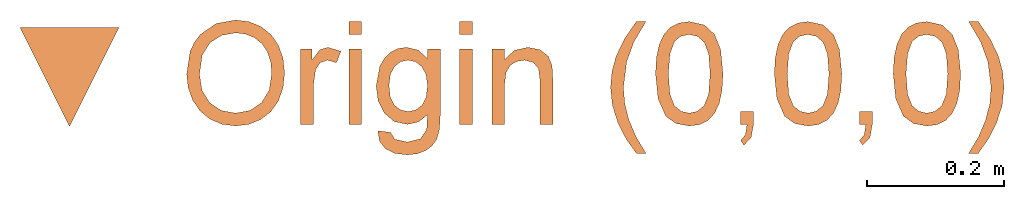
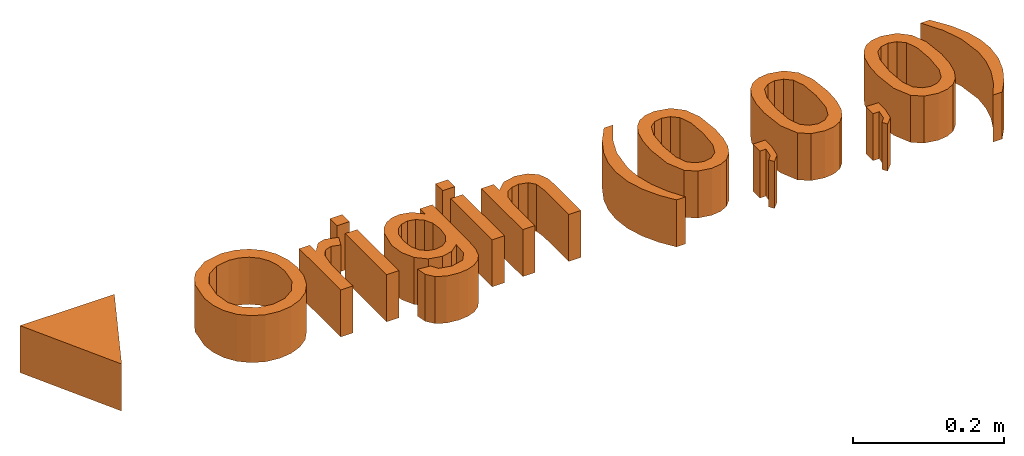
# One storey: 1 proxy.
"""IFC2X3 building model written with IfcOpenShell, lengths in feet."""

from ifc_helpers import new_model, entity, si_unit, converted_unit, derived_unit, direction, frame, frame_2d, origin, origin_2d_with_axis, place, context, subcontext, project, spatial, polyline, rectangle, outline, extrude, source, transform, mapped, element, save


model = new_model("IFC2X3")

# Units and contexts
model_context = context("Model", 3, precision=0.0001, world=origin(), true_north=direction((6.12303176911189e-17, 1.0)))
context_of_model = context(None, 3, precision=0.0001, world=origin(), true_north=direction((6.12303176911189e-17, 1.0)))
body_context = subcontext(model_context, "Body", "Model", "MODEL_VIEW")
ifc_project = project(units=[converted_unit("LENGTHUNIT", "FOOT", entity("IfcRatioMeasure", 0.3048), si_unit("LENGTHUNIT", "METRE"), dimensions=[1, 0, 0, 0, 0, 0, 0]), converted_unit("AREAUNIT", "SQUARE FOOT", entity("IfcRatioMeasure", 0.09290304), si_unit("AREAUNIT", "SQUARE_METRE"), dimensions=[2, 0, 0, 0, 0, 0, 0]), converted_unit("VOLUMEUNIT", "CUBIC FOOT", entity("IfcRatioMeasure", 0.028316846592), si_unit("VOLUMEUNIT", "CUBIC_METRE"), dimensions=[3, 0, 0, 0, 0, 0, 0]), converted_unit("PLANEANGLEUNIT", "DEGREE", entity("IfcRatioMeasure", 0.0174532925199433), si_unit("PLANEANGLEUNIT", "RADIAN"), dimensions=[0, 0, 0, 0, 0, 0, 0]), si_unit("MASSUNIT", "GRAM", prefix="KILO"), derived_unit("MASSDENSITYUNIT", [(si_unit("MASSUNIT", "GRAM", prefix="KILO"), 1), (si_unit("LENGTHUNIT", "METRE"), -3)]), si_unit("TIMEUNIT", "SECOND"), si_unit("FREQUENCYUNIT", "HERTZ"), si_unit("THERMODYNAMICTEMPERATUREUNIT", "DEGREE_CELSIUS"), derived_unit("THERMALTRANSMITTANCEUNIT", [(si_unit("MASSUNIT", "GRAM", prefix="KILO"), 1), (si_unit("THERMODYNAMICTEMPERATUREUNIT", "KELVIN"), -1), (si_unit("TIMEUNIT", "SECOND"), -3)]), derived_unit("VOLUMETRICFLOWRATEUNIT", [(si_unit("LENGTHUNIT", "METRE"), 3), (si_unit("TIMEUNIT", "SECOND"), -1)]), si_unit("ELECTRICCURRENTUNIT", "AMPERE"), si_unit("ELECTRICVOLTAGEUNIT", "VOLT"), si_unit("POWERUNIT", "WATT"), si_unit("FORCEUNIT", "NEWTON"), si_unit("ILLUMINANCEUNIT", "LUX"), si_unit("LUMINOUSFLUXUNIT", "LUMEN"), si_unit("LUMINOUSINTENSITYUNIT", "CANDELA"), derived_unit("USERDEFINED", [(si_unit("MASSUNIT", "GRAM", prefix="KILO"), -1), (si_unit("LENGTHUNIT", "METRE"), -2), (si_unit("TIMEUNIT", "SECOND"), 3), (si_unit("LUMINOUSFLUXUNIT", "LUMEN"), 1)]), derived_unit("LINEARVELOCITYUNIT", [(si_unit("LENGTHUNIT", "METRE"), 1), (si_unit("TIMEUNIT", "SECOND"), -1)]), si_unit("PRESSUREUNIT", "PASCAL"), derived_unit("USERDEFINED", [(si_unit("LENGTHUNIT", "METRE"), -2), (si_unit("MASSUNIT", "GRAM", prefix="KILO"), 1), (si_unit("TIMEUNIT", "SECOND"), -2)])], contexts=[model_context, context_of_model])

# Site, building, storey
site_placement = place(None, origin())
site = spatial("IfcSite", under=ifc_project, at=site_placement, CompositionType="ELEMENT")
building_placement = place(site_placement, origin())
building = spatial("IfcBuilding", under=site, at=building_placement, CompositionType="ELEMENT")
storey_placement = place(building_placement, origin())
storey = spatial("IfcBuildingStorey", under=building, at=storey_placement, Name="Level 1", CompositionType="ELEMENT", Elevation=0.0)

# Proxy
shared_shape = source(origin(), body_context, "Body", "SweptSolid", [
    extrude(outline(polyline([(-0.237339743589744, -0.158092948717949), (0.23729967948718, -0.158092948717949), (4.00641025640932e-05, 0.316185897435897), (-0.237339743589744, -0.158092948717949)])), frame((4.00627327112509e-05, 0.316185891693371, 0.0), z_axis=(0.0, 0.0, 1.0), x_axis=(-1.0, 0.0, 0.0)), (0.0, 0.0, 1.0), 0.25),
    extrude(outline(polyline([(-0.0284612590226709, -0.237236766736656), (0.0348958522134415, -0.237236766736656), (0.0964391339621549, -0.222884314262997), (0.151747049525812, -0.194108953562902), (0.196398062206756, -0.150840228883591), (0.227810757445189, -0.0957528936939977), (0.243403720681313, -0.0315217014630533), (0.242732809195667, 0.0307009353460472), (0.226527686790799, 0.090274192162717), (0.194751244490125, 0.143075156945339), (0.14736637331706, 0.184980917652296), (0.0874299679700298, 0.214395371455753), (0.0179989231474593, 0.229722415527873), (-0.0521353752584369, 0.230358270146238), (-0.116092739154101, 0.215912574956069), (-0.171321220986774, 0.186765525958248), (-0.215268873203699, 0.143297319153657), (-0.245883394115417, 0.0884534368064146), (-0.261112482032469, 0.0251793611806376), (-0.254395778646813, -0.0703569081190312), (-0.21122305420589, -0.150795253488009), (-0.176775166393731, -0.183531366842411), (-0.134832237925808, -0.208850323501987), (-0.0284612590226709, -0.237236766736656)]), holes=[polyline([(-0.0210345899461735, -0.176145130732047), (-0.111124208446177, -0.153174738354658), (-0.167816709946366, -0.10811317555604), (-0.195838038045926, -0.048354234911547), (-0.199914136344041, 0.0187082910034684), (-0.188699305556176, 0.0653932967111734), (-0.166179297730715, 0.105827128579338), (-0.133689266483709, 0.137800562685148), (-0.092564365431212, 0.159104375105785), (-0.0440291801124433, 0.169467142321561), (0.0106917039333779, 0.168617440812786), (0.0902933017335633, 0.147438037518717), (0.146339805637628, 0.104308054666897), (0.177440676454445, 0.0449157468633535), (0.182205374992885, -0.0250506312858839), (0.162353996372651, -0.0912704350013721), (0.119286506661985, -0.142289816201652), (0.0568684598820047, -0.172463229805589), (-0.0210345899461735, -0.176145130732047)])]), frame((0.79998758746794, 0.248042623333561, 0.0), z_axis=(0.0, 0.0, 1.0), x_axis=(0.110978071171783, -0.99382285530118, 0.0)), (0.0, 0.0, 1.0), 0.25),
    extrude(outline(polyline([(-0.0854705991124263, -0.266013313609468), (-0.0239321375739648, -0.266013313609468), (-0.0239321375739647, -0.075989275147929), (-0.0139561760355031, -0.004114275147929), (0.00821930473372757, 0.0295395710059171), (0.0430149778106506, 0.0416789940828402), (0.0862842085798814, 0.0290588017751479), (0.106837093195266, 0.0842270710059171), (0.0450582470414198, 0.103217455621302), (0.00659670857988128, 0.0913184171597632), (-0.0316244452662724, 0.0420395710059172), (-0.0316244452662724, 0.0955251479289941), (-0.0854705991124262, 0.0955251479289941), (-0.0854705991124263, -0.266013313609468)])), frame((1.19268213620411, 0.27634984632848, 0.0)), (0.0, 0.0, 1.0), 0.25),
    extrude(rectangle(XDim=0.0615384615384615, YDim=0.361538461538462, at=frame_2d((-1.11022302462516e-16, 0.0), x_axis=(1.0, 0.0))), frame((1.36874999863015, 0.191105763488243, 0.0)), (0.0, 0.0, 1.0), 0.25),
    extrude(outline(polyline([(0.0760437616075449, -0.157225708562354), (0.127352808461117, -0.157225708562354), (0.167803589273547, -0.134881842298021), (0.196773089934082, -0.0941421006271512), (0.21363829633197, -0.0389544744075394), (0.21699445941854, 0.0103398046945594), (0.208842841223394, 0.0530585569483774), (0.190471795228662, 0.088277168316664), (0.163169674916477, 0.115071024762169), (0.118559813652583, 0.135608067399272), (0.0482655448027257, 0.152056237342352), (-0.259292032766294, 0.2053418443922), (-0.269797319947473, 0.144706696253833), (-0.224320958843698, 0.136827730867949), (-0.27166857950573, 0.10011070585022), (-0.294304178161005, 0.0483167375925892), (-0.295636163483372, 0.00577726389828608), (-0.284243515181167, -0.0330201394038126), (-0.260916621532675, -0.0669169277355704), (-0.22644587081618, -0.0947545565188508), (-0.135479141371354, -0.128385405308961), (-0.0650568805110305, -0.130629497578258), (-0.00182512756474454, -0.111714100603975), (0.0459543198572848, -0.0719765758803923), (0.0700196641448383, -0.0117542849017917), (0.0676682959707075, 0.0422645728642341), (0.0409578142616557, 0.0908670994502903), (0.11094120954928, 0.0744727896221521), (0.148682619375049, 0.0374382173678975), (0.153208329583861, -0.0272649069892827), (0.129510019785385, -0.0837845669230988), (0.0941284423060199, -0.0979037213216348), (0.0760437616075449, -0.157225708562354)]), holes=[polyline([(-0.129118835019946, -0.0670321223046932), (-0.179809706946498, -0.0514949199007369), (-0.213691155065824, -0.0253604154365575), (-0.231177774244575, 0.00757026505707299), (-0.232684159349403, 0.0434959955493819), (-0.218951079428302, 0.0774370844085815), (-0.190924484919526, 0.103229559765807), (-0.149563326068536, 0.11692264163373), (-0.0958265531207925, 0.114565550025021), (-0.0424562471578521, 0.098564124725607), (-0.00811589044665877, 0.0723501124727028), (0.00883091778673326, 0.0392079992432841), (0.0100205783162697, 0.00242227101432749), (-0.00356541241565285, -0.0320779767266449), (-0.0307814128544319, -0.0574162243024498), (-0.072381271041914, -0.0701988225496207), (-0.129118835019946, -0.0670321223046932)])]), frame((1.61837862317943, 0.0813349739750221, 0.0), z_axis=(0.0, 0.0, 1.0), x_axis=(0.170710916694161, -0.985321157248457, 0.0)), (0.0, 0.0, 1.0), 0.25),
    extrude(rectangle(XDim=0.0615384615384618, YDim=0.361538461538462, at=origin_2d_with_axis()), frame((1.89951922939938, 0.191105763488243, 0.0)), (0.0, 0.0, 1.0), 0.25),
    extrude(outline(polyline([(-0.153405448717949, -0.240848214285714), (-0.0918669871794875, -0.240848214285714), (-0.0918669871794875, -0.0490212912087912), (-0.0848507612179494, 0.00767942994505496), (-0.0638020833333339, 0.0426854395604396), (-0.0330779246794877, 0.060804429945055), (0.00296474358974309, 0.0668440934065934), (0.0452123397435895, 0.0560868818681319), (0.0702724358974356, 0.0273008241758242), (0.0773637820512816, -0.0271462912087912), (0.0773637820512815, -0.240848214285714), (0.138902243589743, -0.240848214285714), (0.138902243589743, -0.018853021978022), (0.135657051282051, 0.0406421703296703), (0.117207532051282, 0.0858945741758242), (0.0775440705128201, 0.116663804945055), (0.0194310897435895, 0.128382554945055), (-0.0448116987179494, 0.113839285714286), (-0.0918669871794875, 0.070209478021978), (-0.0918669871794875, 0.120690247252747), (-0.153405448717949, 0.120690247252747), (-0.153405448717949, -0.240848214285714)])), frame((2.17600160119425, 0.251184747004727, 0.0)), (0.0, 0.0, 1.0), 0.25),
    extrude(outline(polyline([(0.0446373020361994, -0.304904906674208), (0.0907911481900459, -0.304904906674208), (0.0436757635746607, -0.226103824943439), (0.0100219174208149, -0.147272695135747), (-0.0101703902714929, -0.0684115172511312), (-0.0169011595022619, 0.0104797087104072), (-0.00139635180995423, 0.133917208710407), (0.0332190328054303, 0.228388362556561), (0.0907911481900459, 0.325864324095023), (0.0446373020361994, 0.325864324095023), (-0.0120333710407232, 0.243352304864253), (-0.0517569287330311, 0.160479708710407), (-0.0717689479638004, 0.087312641402715), (-0.0784396210407237, 0.0108402856334842), (-0.0695153421945696, -0.0763592335972851), (-0.0427425056561082, -0.160553945135747), (-0.0030489960407234, -0.237987839366516), (0.0446373020361994, -0.304904906674208)])), frame((2.67026654274779, 0.176779900931682, 0.0)), (0.0, 0.0, 1.0), 0.25),
    extrude(outline(polyline([(-0.0175401354199926, -0.161552141992614), (0.102827408860543, -0.161552141992614), (0.189403609876265, -0.133445044330139), (0.229322707770302, -0.0887205877136824), (0.247493135932088, -0.0263043770389096), (0.245848984825306, 0.0238685923984784), (0.229825490354175, 0.0660595620197681), (0.199226007880224, 0.100560511476408), (0.153853892764979, 0.127663420419845), (0.0928526376093191, 0.147410673718943), (0.0153657350141229, 0.159844656242567), (-0.100856238293814, 0.160507601948283), (-0.17625202275613, 0.139229970217118), (-0.226803215545482, 0.094506683769593), (-0.249906670860454, 0.0246213748234121), (-0.248279813500272, -0.0252779776134403), (-0.23238165087259, -0.0673654998006099), (-0.201921272230271, -0.101897514992033), (-0.156607766826178, -0.129130346441647), (-0.0954708245821416, -0.149027415118742), (-0.0175401354199926, -0.161552141992614)]), holes=[polyline([(-0.0113919178366473, -0.100321462466257), (-0.105688900957947, -0.0831760872855641), (-0.163075995607727, -0.0548279348233741), (-0.184494812721025, -0.0215236818770309), (-0.188761683705019, 0.0176361864113292), (-0.17532149092052, 0.0571579069382473), (-0.144157754488421, 0.0862867571053433), (-0.0858609660112963, 0.101340890385289), (0.00897838290828126, 0.0986384602507591), (0.10439090082302, 0.0816205134661814), (0.157950564178225, 0.0543891522288146), (0.181348215714639, 0.019613681891151), (0.186274698173006, -0.0200365921943162), (0.173445442336013, -0.0578689638395057), (0.143575878986351, -0.087190726856337), (0.0856390712276032, -0.103006640110143), (-0.0113919178366473, -0.100321462466257)])]), frame((2.96971003468784, 0.251529441372859, 0.0), z_axis=(0.0, 0.0, 1.0), x_axis=(0.101851503724643, -0.994799613585082, 0.0)), (0.0, 0.0, 1.0), 0.25),
    extrude(outline(polyline([(-0.0269097222222223, -0.0185697115384615), (-0.0269097222222223, -0.0801081730769231), (0.0346287393162394, -0.0801081730769231), (0.0346287393162394, -0.0185697115384615), (0.0235710470085468, 0.0443509615384616), (-0.0115251068376065, 0.0814302884615385), (-0.0269097222222223, 0.0583533653846154), (-0.00431356837606822, 0.0317908653846154), (0.00373931623931645, -0.0185697115384615), (-0.0269097222222223, -0.0185697115384615)])), frame((3.24181356700622, -0.00823317881944908, 0.0), z_axis=(0.0, 0.0, -1.0), x_axis=(1.0, 0.0, 0.0)), (0.0, 0.0, -1.0), 0.25),
    extrude(outline(polyline([(-0.017540135419993, -0.161552141992613), (0.102827408860542, -0.161552141992613), (0.189403609876264, -0.133445044330138), (0.229322707770302, -0.0887205877136825), (0.247493135932088, -0.0263043770389093), (0.245848984825306, 0.0238685923984791), (0.229825490354176, 0.0660595620197689), (0.199226007880224, 0.100560511476408), (0.15385389276498, 0.127663420419845), (0.0928526376093199, 0.147410673718944), (0.0153657350141237, 0.159844656242568), (-0.100856238293813, 0.160507601948284), (-0.17625202275613, 0.13922997021712), (-0.226803215545481, 0.0945066837695949), (-0.249906670860453, 0.0246213748234145), (-0.248279813500272, -0.0252779776134374), (-0.23238165087259, -0.0673654998006071), (-0.201921272230271, -0.101897514992031), (-0.156607766826178, -0.129130346441645), (-0.095470824582142, -0.149027415118741), (-0.017540135419993, -0.161552141992613)]), holes=[polyline([(-0.0113919178366475, -0.100321462466256), (-0.105688900957947, -0.0831760872855619), (-0.163075995607727, -0.0548279348233717), (-0.184494812721025, -0.0215236818770287), (-0.188761683705019, 0.0176361864113314), (-0.17532149092052, 0.0571579069382494), (-0.144157754488421, 0.0862867571053448), (-0.0858609660112957, 0.101340890385291), (0.00897838290828181, 0.0986384602507604), (0.10439090082302, 0.0816205134661827), (0.157950564178226, 0.0543891522288153), (0.18134821571464, 0.0196136818911515), (0.186274698173006, -0.0200365921943156), (0.173445442336013, -0.0578689638395056), (0.143575878986351, -0.0871907268563363), (0.085639071227603, -0.103006640110142), (-0.0113919178366475, -0.100321462466256)])]), frame((3.53894080391861, 0.251529441372859, 0.0), z_axis=(0.0, 0.0, 1.0), x_axis=(0.101851503724647, -0.994799613585082, 0.0)), (0.0, 0.0, 1.0), 0.25),
    extrude(outline(polyline([(-0.0269097222222214, -0.0185697115384615), (-0.0269097222222214, -0.0801081730769231), (0.0346287393162399, -0.0801081730769231), (0.0346287393162399, -0.0185697115384615), (0.0235710470085477, 0.0443509615384616), (-0.0115251068376061, 0.0814302884615385), (-0.0269097222222214, 0.0583533653846154), (-0.00431356837606778, 0.0317908653846154), (0.00373931623931689, -0.0185697115384615), (-0.0269097222222214, -0.0185697115384615)])), frame((3.81104433623698, -0.00823317881944908, 0.0), z_axis=(0.0, 0.0, -1.0), x_axis=(1.0, 0.0, 0.0)), (0.0, 0.0, -1.0), 0.25),
    extrude(outline(polyline([(-0.017540135419993, -0.161552141992613), (0.102827408860542, -0.161552141992613), (0.189403609876264, -0.133445044330139), (0.229322707770302, -0.088720587713683), (0.247493135932088, -0.0263043770389097), (0.245848984825306, 0.0238685923984787), (0.229825490354176, 0.0660595620197685), (0.199226007880224, 0.100560511476408), (0.15385389276498, 0.127663420419845), (0.0928526376093198, 0.147410673718944), (0.0153657350141236, 0.159844656242567), (-0.100856238293813, 0.160507601948284), (-0.17625202275613, 0.139229970217119), (-0.226803215545481, 0.0945066837695953), (-0.249906670860453, 0.024621374823414), (-0.248279813500272, -0.0252779776134375), (-0.23238165087259, -0.0673654998006076), (-0.201921272230271, -0.101897514992032), (-0.156607766826178, -0.129130346441645), (-0.095470824582142, -0.149027415118741), (-0.017540135419993, -0.161552141992613)]), holes=[polyline([(-0.0113919178366476, -0.100321462466257), (-0.105688900957947, -0.0831760872855623), (-0.163075995607727, -0.0548279348233721), (-0.184494812721025, -0.0215236818770292), (-0.188761683705019, 0.0176361864113309), (-0.17532149092052, 0.0571579069382485), (-0.144157754488421, 0.0862867571053443), (-0.0858609660112958, 0.101340890385291), (0.00897838290828177, 0.09863846025076), (0.10439090082302, 0.0816205134661823), (0.157950564178226, 0.0543891522288153), (0.18134821571464, 0.0196136818911511), (0.186274698173006, -0.0200365921943161), (0.173445442336013, -0.0578689638395056), (0.143575878986351, -0.0871907268563367), (0.085639071227603, -0.103006640110142), (-0.0113919178366476, -0.100321462466257)])]), frame((4.10817157314938, 0.251529441372859, 0.0), z_axis=(0.0, 0.0, 1.0), x_axis=(0.101851503724647, -0.994799613585082, 0.0)), (0.0, 0.0, 1.0), 0.25),
    extrude(outline(polyline([(-0.274424529277718, -0.139917530051431), (-0.192385303992241, -0.139917530051431), (-0.106235301582955, -0.127534479595469), (-0.0219933481621939, -0.100774695498052), (0.0543217301577047, -0.0576444945736846), (0.11283897436004, -0.00796299693966366), (0.160942017264732, 0.0506884984838158), (0.205558160251711, 0.13103293210543), (0.240076027305162, 0.224992047462114), (0.213375326511488, 0.262638429651105), (0.16659759414109, 0.158436788596124), (0.109259044514686, 0.0757735843031975), (0.0184266834052875, -0.00765791754664634), (-0.0498165024117563, -0.0478075922363973), (-0.125822883263551, -0.0769596888522796), (-0.209592459150096, -0.0951142073942939), (-0.301125230071392, -0.10227114786244), (-0.274424529277718, -0.139917530051431)])), frame((4.39799738267992, 0.17665970862399, 0.0), z_axis=(0.0, 0.0, 1.0), x_axis=(0.578515183862937, 0.815671614094809, 0.0)), (0.0, 0.0, 1.0), 0.25),
    extrude(rectangle(XDim=0.0615384615384615, YDim=0.0615384615384615, at=frame_2d((-1.11022302462516e-16, 0.0), x_axis=(1.0, 0.0))), frame((1.36874999863015, 0.471874994257474, 0.0)), (0.0, 0.0, 1.0), 0.25),
    extrude(rectangle(XDim=0.0615384615384618, YDim=0.0615384615384615, at=origin_2d_with_axis()), frame((1.89951922939938, 0.471874994257474, 0.0)), (0.0, 0.0, 1.0), 0.25),
])
proxy_placement = place(storey_placement, origin())
element("IfcBuildingElementProxy", 1, at=proxy_placement, inside=storey, Name="Origin Marker:Origin Marker", ObjectType="Origin Marker", context=body_context, shape_type="MappedRepresentation", body=[
    mapped(shared_shape, transform((0.0, 0.0, 0.0), scale=1.0)),
])

save(model, "model.ifc")
